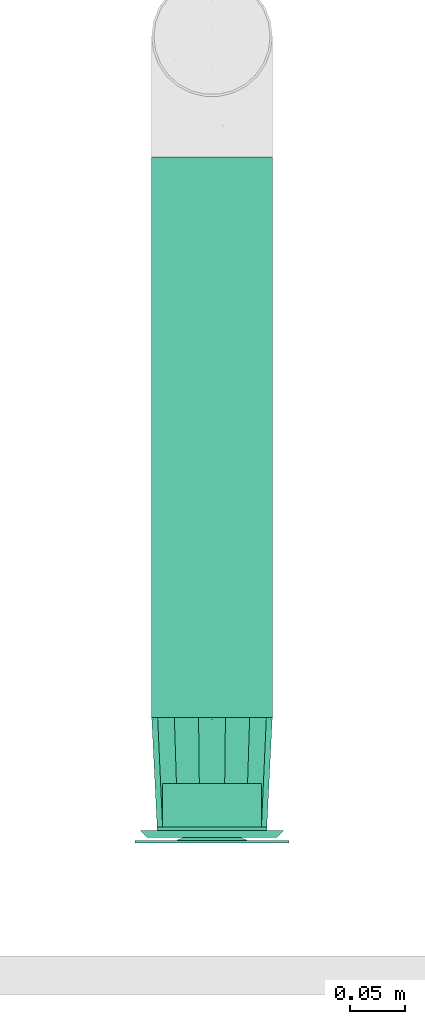
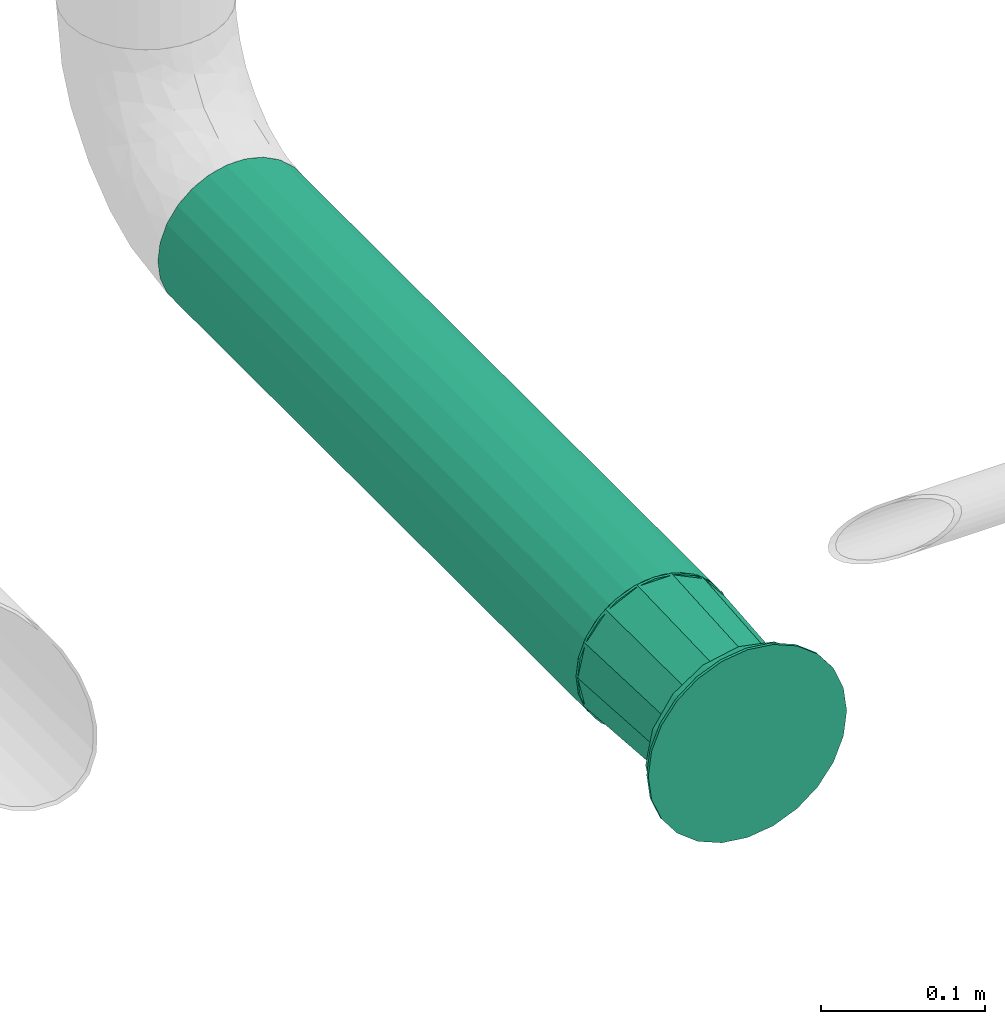
# One storey, part 104 of 123: 1 flow fitting, 1 flow segment, 1 flow terminal.
"""IFC2X3 building model written with IfcOpenShell, lengths in millimetres."""

from ifc_helpers import new_model, entity, si_unit, converted_unit, derived_unit, direction, frame, origin_with_axes, origin_2d_with_axis, place, context, subcontext, project, spatial, hollow_circle, extrude, open_shell, surface_model, source, transform, mapped, material, layer, layer_set, layer_usage, type_object, element, save


model = new_model("IFC2X3")

# Units and contexts
model_context = context("Model", 3, precision=1e-05, world=origin_with_axes(), true_north=direction((0.0, 1.0)))
body_context = subcontext(model_context, "Body", "Model", "MODEL_VIEW")
ifc_project = project(units=[si_unit("AREAUNIT", "SQUARE_METRE"), si_unit("VOLUMEUNIT", "CUBIC_METRE", prefix="DECI"), si_unit("TIMEUNIT", "SECOND"), si_unit("THERMODYNAMICTEMPERATUREUNIT", "DEGREE_CELSIUS"), si_unit("PRESSUREUNIT", "PASCAL"), si_unit("MASSUNIT", "GRAM", prefix="KILO"), si_unit("LENGTHUNIT", "METRE", prefix="MILLI"), si_unit("POWERUNIT", "WATT"), si_unit("ELECTRICCURRENTUNIT", "AMPERE"), si_unit("ELECTRICVOLTAGEUNIT", "VOLT"), derived_unit("VOLUMETRICFLOWRATEUNIT", [(si_unit("VOLUMEUNIT", "CUBIC_METRE", prefix="DECI"), 1), (si_unit("TIMEUNIT", "SECOND"), -1)]), derived_unit("LINEARVELOCITYUNIT", [(si_unit("LENGTHUNIT", "METRE"), 1), (si_unit("TIMEUNIT", "SECOND"), -1)]), derived_unit("MASSDENSITYUNIT", [(si_unit("MASSUNIT", "GRAM", prefix="KILO"), 1), (si_unit("VOLUMEUNIT", "CUBIC_METRE"), -1)]), converted_unit("PLANEANGLEUNIT", "DEGREE", entity("IfcRatioMeasure", 0.01745), si_unit("PLANEANGLEUNIT", "RADIAN"), dimensions=[0, 0, 0, 0, 0, 0, 0])], contexts=[model_context])

# Site, building, storey
site_placement = place(None, origin_with_axes())
site = spatial("IfcSite", under=ifc_project, at=site_placement, CompositionType="ELEMENT")
building_placement = place(site_placement, origin_with_axes())
building = spatial("IfcBuilding", under=site, at=building_placement, Name="mc-building", CompositionType="ELEMENT")
storey_placement = place(building_placement, origin_with_axes())
storey = spatial("IfcBuildingStorey", under=building, at=storey_placement, Name="1. Korrus", CompositionType="ELEMENT", Elevation=0.0)

# Flow terminal
air_terminal_type = type_object("IfcAirTerminalType", Name="100", PredefinedType="NOTDEFINED")
shared_shape_1 = source(origin_with_axes(), body_context, "Body", "SurfaceModel", [
    surface_model("IfcShellBasedSurfaceModel", [(11.2, 18.11733, -67.61481), (11.2, -18.11733, -67.61481), (11.2, 0.0, -70.0), (11.2, 67.61481, -18.11733), (11.2, 35.0, -60.62178), (11.2, 49.49747, -49.49747), (11.2, 60.62178, -35.0), (11.2, -67.61481, 18.11733), (11.2, -49.49747, -49.49747), (11.2, -67.61481, -18.11733), (11.2, -35.0, -60.62178), (11.2, -60.62178, -35.0), (11.2, -70.0, 0.0), (11.2, 18.11733, 67.61481), (11.2, 70.0, 0.0), (11.2, 67.61481, 18.11733), (11.2, 49.49747, 49.49747), (11.2, 60.62178, 35.0), (11.2, 35.0, 60.62178), (11.2, -49.49747, 49.49747), (11.2, -60.62178, 35.0), (11.2, -35.0, 60.62178), (11.2, -18.11733, 67.61481), (11.2, 0.0, 70.0), (9.2, 18.11733, 67.61481), (9.2, -67.61481, 18.11733), (9.2, 0.0, 70.0), (9.2, 49.49747, 49.49747), (9.2, 35.0, 60.62178), (9.2, 60.62178, 35.0), (9.2, 67.61481, 18.11733), (9.2, -35.0, 60.62178), (9.2, -49.49747, 49.49747), (9.2, -18.11733, 67.61481), (9.2, -60.62178, 35.0), (9.2, -67.61481, -18.11733), (9.2, -70.0, 0.0), (9.2, 67.61481, -18.11733), (9.2, 18.11733, -67.61481), (9.2, 49.49747, -49.49747), (9.2, 60.62178, -35.0), (9.2, 35.0, -60.62178), (9.2, -18.11733, -67.61481), (9.2, -49.49747, -49.49747), (9.2, -60.62178, -35.0), (9.2, -35.0, -60.62178), (9.2, 0.0, -70.0), (9.2, 70.0, 0.0), (9.2, 32.75, 0.0), (9.2, -16.375, 28.36233), (9.2, -28.36233, 16.375), (9.2, 16.375, 28.36233), (9.2, 0.0, 32.75), (9.2, 28.36233, 16.375), (9.2, -32.75, 0.0), (9.2, -16.375, -28.36233), (9.2, 16.375, -28.36233), (9.2, 0.0, -32.75), (9.2, 28.36233, -16.375), (9.2, -28.36233, -16.375), (6.2, -21.19625, -15.39997), (6.2, -21.19625, 15.39997), (6.2, 8.09625, 24.91768), (6.2, -8.09625, 24.91768), (6.2, -26.2, 0.0), (6.2, 21.19625, 15.39997), (6.2, -8.09625, -24.91768), (6.2, 21.19625, -15.39997), (6.2, 8.09625, -24.91768), (6.2, 26.2, 0.0), (9.2, 31.06579, -6.28555), (6.2, 23.69812, -7.69999), (6.2, -14.64625, -20.15883), (9.2, -22.36867, -22.36867), (6.2, -23.69812, -7.69999), (9.2, -31.06579, -6.28555), (6.2, 14.64625, -20.15883), (9.2, 8.1875, -30.55617), (6.2, 0.0, -24.91768), (9.2, 22.36867, -22.36867), (9.2, -8.1875, -30.55617), (9.2, -31.06579, 6.28555), (6.2, -23.69812, 7.69999), (6.2, 14.64625, 20.15883), (9.2, 22.36867, 22.36867), (6.2, 23.69812, 7.69999), (9.2, 31.06579, 6.28555), (6.2, -14.64625, 20.15883), (9.2, -8.1875, 30.55617), (6.2, 0.0, 24.91768), (9.2, -22.36867, 22.36867), (9.2, 8.1875, 30.55617), (6.2, -13.11761, 57.472), (6.2, -36.75472, 46.08897), (6.2, -53.11211, 25.57744), (6.2, 36.75472, 46.08897), (6.2, -58.95, 0.0), (6.2, 13.11761, 57.472), (6.2, 53.11211, 25.57744), (6.2, -53.11211, -25.57744), (6.2, -36.75472, -46.08897), (6.2, -13.11761, -57.472), (6.2, 58.95, 0.0), (6.2, 53.11211, -25.57744), (6.2, 13.11761, -57.472), (6.2, 36.75472, -46.08897), (0.0, -60.51411, 25.06576), (0.0, 0.0, 65.5), (0.0, 25.06576, 60.51411), (0.0, 46.3155, 46.3155), (0.0, 60.51411, 25.06576), (0.0, -46.3155, 46.3155), (0.0, -25.06576, 60.51411), (0.0, 0.0, -65.5), (0.0, -65.5, 0.0), (0.0, 65.5, 0.0), (0.0, 60.51411, -25.06576), (0.0, 46.3155, -46.3155), (0.0, 25.06576, -60.51411), (0.0, -46.3155, -46.3155), (0.0, -60.51411, -25.06576), (0.0, -25.06576, -60.51411), (6.2, 56.03105, -12.78872), (0.0, 53.4148, -35.69063), (0.0, 35.69063, -53.4148), (6.2, 24.93616, -51.78048), (0.0, -12.53288, -63.00706), (6.2, 0.0, -57.472), (0.0, -35.69063, -53.4148), (0.0, 63.00706, -12.53288), (6.2, 44.93342, -35.83321), (6.2, -24.93616, -51.78048), (6.2, -44.93342, -35.83321), (0.0, -53.4148, -35.69063), (0.0, 12.53288, -63.00706), (6.2, -56.03105, -12.78872), (0.0, -63.00706, -12.53288), (6.2, -56.03105, 12.78872), (0.0, -53.4148, 35.69063), (0.0, -35.69063, 53.4148), (6.2, -24.93616, 51.78048), (0.0, 12.53288, 63.00706), (6.2, 0.0, 57.472), (0.0, 35.69063, 53.4148), (0.0, -63.00706, 12.53288), (6.2, -44.93342, 35.83321), (6.2, 24.93616, 51.78048), (6.2, 44.93342, 35.83321), (0.0, 53.4148, 35.69063), (0.0, -12.53288, 63.00706), (6.2, 56.03105, 12.78872), (0.0, 63.00706, 12.53288), (-3.1, 12.94095, 48.29629), (-3.1, -35.35534, 35.35534), (-3.1, 0.0, 50.0), (-3.1, 35.35534, 35.35534), (-3.1, 25.0, 43.30127), (-3.1, -43.30127, 25.0), (-3.1, 43.30127, 25.0), (-3.1, -48.29629, -12.94095), (-3.1, -12.94095, 48.29629), (-3.1, -25.0, 43.30127), (-3.1, -50.0, 0.0), (-3.1, -48.29629, 12.94095), (-3.1, 48.29629, 12.94095), (-3.1, 12.94095, -48.29629), (-3.1, 50.0, 0.0), (-3.1, 48.29629, -12.94095), (-3.1, 35.35534, -35.35534), (-3.1, 43.30127, -25.0), (-3.1, 25.0, -43.30127), (-3.1, 0.0, -50.0), (-3.1, -35.35534, -35.35534), (-3.1, -43.30127, -25.0), (-3.1, -25.0, -43.30127), (-3.1, -12.94095, -48.29629), (0.0, 25.0, -43.30127), (0.0, 0.0, -50.0), (0.0, 12.94095, -48.29629), (0.0, 48.29629, -12.94095), (0.0, 35.35534, -35.35534), (0.0, -25.0, -43.30127), (0.0, 43.30127, -25.0), (0.0, -50.0, 0.0), (0.0, -12.94095, -48.29629), (0.0, -35.35534, -35.35534), (0.0, -48.29629, -12.94095), (0.0, -43.30127, -25.0), (0.0, 50.0, 0.0), (0.0, 43.30127, 25.0), (0.0, 12.94095, 48.29629), (0.0, 35.35534, 35.35534), (0.0, 25.0, 43.30127), (0.0, 0.0, 50.0), (0.0, -35.35534, 35.35534), (0.0, -43.30127, 25.0), (0.0, -48.29629, 12.94095), (0.0, -12.94095, 48.29629), (0.0, -25.0, 43.30127), (0.0, 48.29629, 12.94095), (-43.1, 0.0, 45.0), (-43.1, 11.64686, 43.46666), (-43.1, 22.5, 38.97115), (-43.1, -11.64686, 43.46666), (-43.1, 38.97115, 22.5), (-43.1, 43.46666, 11.64686), (-43.1, 31.81981, 31.81981), (-43.1, -22.5, 38.97115), (-43.1, -43.46666, 11.64686), (-43.1, -31.81981, 31.81981), (-43.1, -38.97115, 22.5), (-43.1, -45.0, 0.0), (-43.1, -43.46666, -11.64686), (-43.1, 45.0, 0.0), (-43.1, 43.46666, -11.64686), (-43.1, 38.97115, -22.5), (-43.1, 31.81981, -31.81981), (-43.1, 22.5, -38.97115), (-43.1, 11.64686, -43.46666), (-43.1, -31.81981, -31.81981), (-43.1, -38.97115, -22.5), (-43.1, -22.5, -38.97115), (-43.1, 0.0, -45.0), (-43.1, -11.64686, -43.46666), (-3.1, 22.5, -38.97115), (-3.1, 0.0, -45.0), (-3.1, 11.64686, -43.46666), (-3.1, 31.81981, -31.81981), (-3.1, -22.5, -38.97115), (-3.1, 38.97115, -22.5), (-3.1, 43.46666, -11.64686), (-3.1, 45.0, 0.0), (-3.1, -45.0, 0.0), (-3.1, -11.64686, -43.46666), (-3.1, -31.81981, -31.81981), (-3.1, -43.46666, -11.64686), (-3.1, -38.97115, -22.5), (-3.1, 0.0, 45.0), (-3.1, 43.46666, 11.64686), (-3.1, 38.97115, 22.5), (-3.1, 22.5, 38.97115), (-3.1, 31.81981, 31.81981), (-3.1, 11.64686, 43.46666), (-3.1, -11.64686, 43.46666), (-3.1, -43.46666, 11.64686), (-3.1, -31.81981, 31.81981), (-3.1, -38.97115, 22.5), (-3.1, -22.5, 38.97115)], [open_shell([[[0, 1, 2]], [[3, 0, 4]], [[5, 6, 3]], [[5, 3, 4]], [[7, 1, 0]], [[8, 7, 9]], [[10, 7, 8]], [[8, 9, 11]], [[12, 9, 7]], [[1, 7, 10]], [[7, 0, 3]], [[13, 14, 15]], [[16, 15, 17]], [[16, 18, 13]], [[16, 13, 15]], [[14, 13, 7]], [[7, 19, 20]], [[19, 7, 21]], [[7, 22, 21]], [[22, 7, 23]], [[7, 13, 23]], [[14, 7, 3]], [[24, 25, 26]], [[27, 24, 28]], [[27, 29, 30]], [[27, 30, 24]], [[25, 24, 30]], [[31, 25, 32]], [[25, 31, 33]], [[32, 25, 34]], [[33, 26, 25]], [[25, 35, 36]], [[25, 30, 37]], [[25, 37, 38]], [[39, 37, 40]], [[39, 41, 38]], [[39, 38, 37]], [[38, 42, 25]], [[35, 43, 44]], [[35, 25, 43]], [[45, 43, 25]], [[42, 45, 25]], [[38, 46, 42]], [[37, 30, 47]], [[35, 9, 36]], [[44, 11, 35]], [[10, 43, 45]], [[44, 43, 8]], [[1, 45, 42]], [[35, 11, 9]], [[9, 12, 36]], [[1, 10, 45]], [[8, 43, 10]], [[8, 11, 44]], [[2, 1, 42]], [[42, 46, 2]], [[38, 0, 46]], [[41, 4, 38]], [[6, 39, 40]], [[41, 39, 5]], [[3, 40, 37]], [[41, 5, 4]], [[4, 0, 38]], [[14, 3, 37]], [[6, 40, 3]], [[6, 5, 39]], [[47, 14, 37]], [[46, 0, 2]], [[30, 15, 47]], [[29, 17, 30]], [[18, 27, 28]], [[29, 27, 16]], [[13, 28, 24]], [[30, 17, 15]], [[15, 14, 47]], [[13, 18, 28]], [[16, 27, 18]], [[16, 17, 29]], [[23, 13, 24]], [[24, 26, 23]], [[33, 22, 26]], [[31, 21, 33]], [[20, 32, 34]], [[31, 32, 19]], [[7, 34, 25]], [[31, 19, 21]], [[21, 22, 33]], [[12, 7, 25]], [[20, 34, 7]], [[20, 19, 32]], [[36, 12, 25]], [[26, 22, 23]], [[48, 49, 50]], [[48, 51, 49]], [[49, 51, 52]], [[53, 51, 48]], [[48, 50, 54]], [[54, 55, 48]], [[56, 55, 57]], [[55, 58, 48]], [[58, 55, 56]], [[55, 54, 59]], [[60, 61, 62]], [[62, 61, 63]], [[64, 61, 60]], [[62, 65, 66]], [[67, 68, 65]], [[66, 60, 62]], [[65, 68, 66]], [[69, 67, 65]], [[69, 48, 70]], [[58, 71, 70]], [[72, 73, 60]], [[59, 74, 60]], [[75, 64, 74]], [[56, 68, 76]], [[72, 66, 55]], [[73, 72, 55]], [[68, 77, 78]], [[64, 75, 54]], [[59, 75, 74]], [[70, 71, 69]], [[67, 79, 76]], [[80, 55, 66]], [[68, 56, 77]], [[56, 76, 79]], [[79, 67, 58]], [[71, 58, 67]], [[80, 78, 57]], [[77, 57, 78]], [[66, 78, 80]], [[59, 60, 73]], [[64, 54, 81]], [[50, 82, 81]], [[83, 84, 65]], [[53, 85, 65]], [[86, 69, 85]], [[49, 63, 87]], [[83, 62, 51]], [[84, 83, 51]], [[63, 88, 89]], [[69, 86, 48]], [[53, 86, 85]], [[81, 82, 64]], [[61, 90, 87]], [[91, 51, 62]], [[63, 49, 88]], [[49, 87, 90]], [[90, 61, 50]], [[82, 50, 61]], [[91, 89, 52]], [[88, 52, 89]], [[62, 89, 91]], [[53, 65, 84]], [[92, 93, 94]], [[95, 94, 96]], [[97, 92, 95]], [[95, 92, 94]], [[96, 98, 95]], [[96, 99, 98]], [[99, 100, 101]], [[101, 102, 98]], [[102, 101, 103]], [[104, 105, 103]], [[101, 104, 103]], [[101, 98, 99]], [[106, 107, 108]], [[109, 110, 108]], [[106, 108, 110]], [[111, 112, 106]], [[106, 112, 107]], [[106, 113, 114]], [[106, 110, 113]], [[115, 116, 117]], [[117, 113, 110]], [[113, 117, 118]], [[114, 119, 120]], [[121, 119, 114]], [[121, 114, 113]], [[115, 117, 110]], [[103, 116, 122]], [[123, 116, 103]], [[124, 125, 118]], [[101, 126, 127]], [[100, 119, 128]], [[102, 122, 129]], [[103, 130, 123]], [[102, 129, 115]], [[113, 127, 126]], [[125, 124, 105]], [[130, 105, 117]], [[118, 125, 104]], [[124, 117, 105]], [[131, 100, 128]], [[119, 100, 132]], [[133, 99, 120]], [[134, 118, 104]], [[122, 116, 129]], [[127, 134, 104]], [[131, 121, 101]], [[99, 133, 132]], [[128, 121, 131]], [[130, 117, 123]], [[101, 121, 126]], [[99, 135, 120]], [[96, 136, 135]], [[136, 120, 135]], [[134, 127, 113]], [[133, 119, 132]], [[136, 96, 114]], [[94, 106, 137]], [[138, 106, 94]], [[139, 140, 112]], [[97, 141, 142]], [[95, 109, 143]], [[96, 137, 144]], [[94, 145, 138]], [[96, 144, 114]], [[107, 142, 141]], [[140, 139, 93]], [[145, 93, 111]], [[112, 140, 92]], [[139, 111, 93]], [[146, 95, 143]], [[109, 95, 147]], [[148, 98, 110]], [[149, 112, 92]], [[137, 106, 144]], [[142, 149, 92]], [[146, 108, 97]], [[98, 148, 147]], [[143, 108, 146]], [[145, 111, 138]], [[97, 108, 141]], [[98, 150, 110]], [[102, 151, 150]], [[151, 110, 150]], [[149, 142, 107]], [[148, 109, 147]], [[151, 102, 115]], [[152, 153, 154]], [[155, 152, 156]], [[157, 152, 158]], [[158, 152, 155]], [[158, 159, 157]], [[160, 153, 161]], [[160, 154, 153]], [[157, 162, 163]], [[153, 152, 157]], [[157, 159, 162]], [[158, 164, 159]], [[165, 166, 167]], [[168, 167, 169]], [[170, 165, 167]], [[170, 167, 168]], [[166, 165, 171]], [[159, 172, 173]], [[172, 159, 174]], [[174, 171, 175]], [[159, 164, 174]], [[166, 171, 174]], [[174, 164, 166]], [[176, 177, 178]], [[179, 176, 180]], [[176, 179, 181]], [[179, 180, 182]], [[179, 183, 181]], [[177, 181, 184]], [[177, 176, 181]], [[185, 186, 187]], [[186, 185, 181]], [[181, 183, 186]], [[183, 179, 188]], [[183, 188, 189]], [[190, 189, 191]], [[189, 190, 183]], [[190, 191, 192]], [[193, 194, 190]], [[183, 195, 196]], [[183, 190, 195]], [[194, 197, 198]], [[194, 195, 190]], [[197, 194, 193]], [[189, 188, 199]], [[164, 199, 166]], [[158, 189, 164]], [[192, 155, 156]], [[158, 155, 191]], [[190, 156, 152]], [[164, 189, 199]], [[199, 188, 166]], [[190, 192, 156]], [[191, 155, 192]], [[191, 189, 158]], [[193, 190, 152]], [[152, 154, 193]], [[160, 197, 154]], [[161, 198, 160]], [[195, 153, 157]], [[161, 153, 194]], [[196, 157, 163]], [[161, 194, 198]], [[198, 197, 160]], [[183, 196, 163]], [[195, 157, 196]], [[195, 194, 153]], [[162, 183, 163]], [[154, 197, 193]], [[159, 186, 162]], [[173, 187, 159]], [[181, 172, 174]], [[173, 172, 185]], [[184, 174, 175]], [[159, 187, 186]], [[186, 183, 162]], [[184, 181, 174]], [[185, 172, 181]], [[185, 187, 173]], [[177, 184, 175]], [[175, 171, 177]], [[165, 178, 171]], [[170, 176, 165]], [[182, 168, 169]], [[170, 168, 180]], [[179, 169, 167]], [[170, 180, 176]], [[176, 178, 165]], [[188, 179, 167]], [[182, 169, 179]], [[182, 180, 168]], [[166, 188, 167]], [[171, 178, 177]], [[200, 201, 202]], [[203, 200, 202]], [[204, 205, 202]], [[204, 202, 206]], [[203, 202, 205]], [[207, 208, 209]], [[207, 203, 205]], [[209, 208, 210]], [[211, 208, 212]], [[208, 207, 212]], [[207, 205, 212]], [[213, 214, 215]], [[205, 215, 212]], [[212, 216, 217]], [[216, 212, 215]], [[218, 219, 217]], [[212, 219, 220]], [[212, 217, 219]], [[221, 222, 223]], [[222, 221, 219]], [[218, 222, 219]], [[215, 205, 213]], [[224, 225, 226]], [[227, 228, 224]], [[229, 230, 231]], [[228, 227, 229]], [[229, 232, 228]], [[225, 228, 233]], [[225, 224, 228]], [[234, 235, 236]], [[235, 234, 228]], [[228, 232, 235]], [[232, 229, 231]], [[237, 238, 239]], [[240, 239, 241]], [[240, 242, 237]], [[240, 237, 239]], [[238, 237, 243]], [[244, 245, 246]], [[247, 244, 232]], [[244, 247, 245]], [[232, 238, 247]], [[238, 243, 247]], [[238, 232, 231]], [[205, 238, 213]], [[204, 239, 205]], [[240, 206, 202]], [[204, 206, 241]], [[242, 202, 201]], [[205, 239, 238]], [[238, 231, 213]], [[240, 202, 242]], [[241, 206, 240]], [[241, 239, 204]], [[201, 237, 242]], [[201, 200, 237]], [[243, 203, 207]], [[209, 247, 207]], [[246, 210, 208]], [[209, 210, 245]], [[244, 208, 211]], [[203, 243, 200]], [[207, 247, 243]], [[200, 243, 237]], [[209, 245, 247]], [[210, 246, 245]], [[244, 246, 208]], [[211, 232, 244]], [[212, 235, 211]], [[220, 236, 212]], [[228, 219, 221]], [[220, 219, 234]], [[233, 221, 223]], [[212, 236, 235]], [[235, 232, 211]], [[233, 228, 221]], [[234, 219, 228]], [[234, 236, 220]], [[225, 233, 223]], [[223, 222, 225]], [[226, 218, 217]], [[216, 224, 217]], [[229, 215, 214]], [[216, 215, 227]], [[230, 214, 213]], [[218, 226, 222]], [[217, 224, 226]], [[222, 226, 225]], [[216, 227, 224]], [[215, 229, 227]], [[230, 229, 214]], [[213, 231, 230]]])]),
])
flow_terminal_placement = place(storey_placement, frame((30364.56773, 12939.66532, 2300.0), z_axis=(0.0, 0.0, 1.0), x_axis=(0.0, -1.0, 0.0)))
element("IfcFlowTerminal", 1, at=flow_terminal_placement, inside=storey, type_object=air_terminal_type, Name="100", context=body_context, shape_type="MappedRepresentation", body=[
    mapped(shared_shape_1, transform((0.0, 0.0, 0.0), scale=1.0)),
])

# Flow segment
ifc_material = material(Name="FZ1")
ifc_layer = layer(ifc_material, 0.0)
ifc_layer_set = layer_set([ifc_layer], Name="FZ1")
ifc_layer_usage = layer_usage(ifc_layer_set, "AXIS1", "POSITIVE", 0.0)
duct_segment_type = type_object("IfcDuctSegmentType", PredefinedType="RIGIDSEGMENT")
shared_shape_2 = source(origin_with_axes(), body_context, "Body", "SweptSolid", [
    extrude(hollow_circle(Radius=55.0, WallThickness=2.0, at=origin_2d_with_axis()), frame((0.0, 0.0, 0.0), z_axis=(1.0, 0.0, 0.0), x_axis=(0.0, 1.0, 0.0)), (0.0, 0.0, 1.0), 510.8),
])
flow_segment_placement = place(storey_placement, frame((30364.56773, 13042.76532, 2300.0), z_axis=(0.0, 0.0, 1.0), x_axis=(0.0, 1.0, 0.0)))
element("IfcFlowSegment", 2, at=flow_segment_placement, inside=storey, type_object=duct_segment_type, material=ifc_layer_usage, context=body_context, shape_type="MappedRepresentation", body=[
    mapped(shared_shape_2, transform((0.0, 0.0, 0.0), scale=1.0)),
])

# Flow fitting
duct_fitting_type = type_object("IfcDuctFittingType", PredefinedType="TRANSITION")
shared_shape_3 = source(origin_with_axes(), body_context, "Body", "SurfaceModel", [
    surface_model("IfcShellBasedSurfaceModel", [(0.0, 12.94095, 48.29629), (0.0, -35.35534, 35.35534), (0.0, 0.0, 50.0), (0.0, 35.35534, 35.35534), (0.0, 25.0, 43.30127), (0.0, 43.30127, 25.0), (0.0, 48.29629, 12.94095), (0.0, -12.94095, 48.29629), (0.0, -25.0, 43.30127), (0.0, -48.29629, 12.94095), (0.0, -43.30127, 25.0), (0.0, -25.0, -43.30127), (0.0, -48.29629, -12.94095), (0.0, -50.0, 0.0), (0.0, 48.29629, -12.94095), (0.0, 12.94095, -48.29629), (0.0, 43.30127, -25.0), (0.0, 35.35534, -35.35534), (0.0, 25.0, -43.30127), (0.0, -35.35534, -35.35534), (0.0, -43.30127, -25.0), (0.0, -12.94095, -48.29629), (0.0, 0.0, -50.0), (0.0, 50.0, 0.0), (100.0, -55.0, 0.0), (100.0, -12.23865, 53.62104), (100.0, -34.29194, 43.00073), (100.0, 49.55329, -23.86361), (100.0, 12.23865, 53.62104), (100.0, 34.29194, 43.00073), (100.0, 55.0, 0.0), (100.0, 49.55329, 23.86361), (100.0, -49.55329, 23.86361), (100.0, 12.23865, -53.62104), (100.0, -49.55329, -23.86361), (100.0, -34.29194, -43.00073), (100.0, 34.29194, -43.00073), (100.0, -12.23865, -53.62104), (0.0, 11.12605, 48.7464), (0.0, -11.12605, 48.7464), (0.0, 31.17449, 39.09157), (0.0, -45.04844, -21.69419), (0.0, -45.04844, 21.69419), (0.0, -31.17449, 39.09157), (0.0, 45.04844, 21.69419), (0.0, 45.04844, -21.69419), (0.0, 31.17449, -39.09157), (0.0, -31.17449, -39.09157), (0.0, -11.12605, -48.7464), (0.0, 11.12605, -48.7464), (0.0, -47.52422, -10.84709), (100.0, -41.92261, -33.43217), (0.0, -38.11147, -30.39288), (100.0, 41.92261, -33.43217), (0.0, 38.11147, -30.39288), (0.0, -21.15027, -43.91899), (100.0, -23.2653, -48.31088), (100.0, -52.32388, -11.72483), (100.0, 0.0, -53.62104), (0.0, 0.0, -48.7464), (100.0, 23.2653, -48.31088), (0.0, 21.15027, -43.91899), (100.0, 52.32388, -11.72483), (0.0, 47.52422, -10.84709), (0.0, 47.52422, 10.84709), (100.0, 41.92261, 33.43217), (0.0, 38.11147, 30.39288), (100.0, -41.92261, 33.43217), (0.0, -38.11147, 30.39288), (0.0, 21.15027, 43.91899), (100.0, 23.2653, 48.31088), (100.0, 52.32388, 11.72483), (100.0, 0.0, 53.62104), (0.0, 0.0, 48.7464), (100.0, -23.2653, 48.31088), (0.0, -21.15027, 43.91899), (100.0, -52.32388, 11.72483), (0.0, -47.52422, 10.84709), (100.0, 27.5, -47.63139), (100.0, 0.0, -55.0), (100.0, 14.23505, -53.12592), (100.0, 38.89087, -38.89087), (100.0, -27.5, -47.63139), (100.0, 47.63139, -27.5), (100.0, 53.12592, -14.23505), (100.0, -14.23505, -53.12592), (100.0, -47.63139, -27.5), (100.0, -38.89087, -38.89087), (100.0, -53.12592, -14.23505), (100.0, 53.12592, 14.23505), (100.0, 47.63139, 27.5), (100.0, 27.5, 47.63139), (100.0, 38.89087, 38.89087), (100.0, 14.23505, 53.12592), (100.0, 0.0, 55.0), (100.0, -47.63139, 27.5), (100.0, -53.12592, 14.23505), (100.0, -27.5, 47.63139), (100.0, -38.89087, 38.89087), (100.0, -14.23505, 53.12592), (98.0, 0.0, 55.0), (98.0, 14.23505, 53.12592), (98.0, 27.5, 47.63139), (98.0, 38.89087, 38.89087), (98.0, 47.63139, 27.5), (98.0, -47.63139, 27.5), (98.0, 53.12592, -14.23505), (98.0, -27.5, 47.63139), (98.0, -14.23505, 53.12592), (98.0, -38.89087, 38.89087), (98.0, -55.0, 0.0), (98.0, -53.12592, 14.23505), (98.0, 53.12592, 14.23505), (98.0, 47.63139, -27.5), (98.0, -27.5, -47.63139), (98.0, 0.0, -55.0), (98.0, 38.89087, -38.89087), (98.0, 27.5, -47.63139), (98.0, 14.23505, -53.12592), (98.0, -47.63139, -27.5), (98.0, -38.89087, -38.89087), (98.0, -53.12592, -14.23505), (98.0, -14.23505, -53.12592), (98.0, 55.0, 0.0), (2.0, 12.94095, -48.29629), (2.0, 25.0, -43.30127), (2.0, 35.35534, -35.35534), (2.0, 43.30127, -25.0), (2.0, 48.29629, -12.94095), (2.0, 0.0, -50.0), (2.0, 50.0, 0.0), (2.0, -25.0, -43.30127), (2.0, -12.94095, -48.29629), (2.0, -35.35534, -35.35534), (2.0, -48.29629, -12.94095), (2.0, -43.30127, -25.0), (2.0, -48.29629, 12.94095), (2.0, 48.29629, 12.94095), (2.0, 43.30127, 25.0), (2.0, 35.35534, 35.35534), (2.0, -35.35534, 35.35534), (2.0, 12.94095, 48.29629), (2.0, 25.0, 43.30127), (2.0, 0.0, 50.0), (2.0, -43.30127, 25.0), (2.0, -50.0, 0.0), (2.0, -12.94095, 48.29629), (2.0, -25.0, 43.30127)], [open_shell([[[0, 1, 2]], [[3, 0, 4]], [[3, 5, 6]], [[0, 3, 1]], [[6, 1, 3]], [[7, 1, 8]], [[7, 2, 1]], [[1, 9, 10]], [[9, 1, 11]], [[12, 13, 9]], [[11, 1, 6]], [[6, 14, 11]], [[15, 14, 16]], [[17, 18, 15]], [[17, 15, 16]], [[11, 14, 15]], [[12, 19, 20]], [[19, 12, 11]], [[15, 21, 11]], [[12, 9, 11]], [[22, 21, 15]], [[14, 6, 23]], [[24, 25, 26]], [[25, 27, 28]], [[29, 28, 27]], [[27, 30, 31]], [[31, 29, 27]], [[24, 26, 32]], [[33, 24, 34]], [[33, 34, 35]], [[36, 27, 33]], [[33, 27, 24]], [[35, 37, 33]], [[24, 27, 25]], [[38, 23, 39]], [[40, 23, 38]], [[41, 42, 43]], [[41, 13, 42]], [[23, 43, 39]], [[40, 44, 23]], [[41, 23, 45]], [[41, 45, 46]], [[47, 41, 48]], [[49, 48, 41]], [[41, 46, 49]], [[23, 41, 43]], [[34, 50, 41]], [[47, 51, 52]], [[45, 27, 53]], [[36, 54, 53]], [[55, 48, 56]], [[34, 57, 50]], [[57, 13, 50]], [[13, 57, 24]], [[55, 35, 47]], [[35, 51, 47]], [[51, 41, 52]], [[58, 59, 49]], [[60, 61, 46]], [[37, 59, 58]], [[62, 63, 23]], [[35, 55, 56]], [[23, 30, 62]], [[53, 54, 45]], [[48, 37, 56]], [[33, 49, 61]], [[49, 33, 58]], [[54, 36, 46]], [[63, 27, 45]], [[34, 41, 51]], [[33, 61, 60]], [[48, 59, 37]], [[27, 63, 62]], [[46, 36, 60]], [[31, 64, 44]], [[40, 65, 66]], [[42, 32, 67]], [[26, 68, 67]], [[69, 38, 70]], [[31, 71, 64]], [[71, 23, 64]], [[23, 71, 30]], [[69, 29, 40]], [[29, 65, 40]], [[65, 44, 66]], [[72, 73, 39]], [[74, 75, 43]], [[28, 73, 72]], [[76, 77, 13]], [[29, 69, 70]], [[13, 24, 76]], [[67, 68, 42]], [[38, 28, 70]], [[25, 39, 75]], [[39, 25, 72]], [[68, 26, 43]], [[77, 32, 42]], [[31, 44, 65]], [[25, 75, 74]], [[38, 73, 28]], [[32, 77, 76]], [[43, 26, 74]], [[78, 79, 80]], [[81, 82, 78]], [[82, 83, 84]], [[81, 83, 82]], [[30, 82, 84]], [[79, 82, 85]], [[79, 78, 82]], [[82, 86, 87]], [[82, 30, 86]], [[24, 88, 86]], [[86, 30, 89]], [[90, 24, 89]], [[91, 90, 92]], [[91, 93, 94]], [[90, 91, 24]], [[94, 95, 91]], [[24, 95, 96]], [[24, 91, 95]], [[94, 97, 98]], [[98, 95, 94]], [[97, 94, 99]], [[89, 24, 86]], [[100, 101, 102]], [[100, 102, 103]], [[100, 104, 105]], [[104, 100, 103]], [[106, 105, 104]], [[100, 107, 108]], [[100, 109, 107]], [[105, 110, 111]], [[109, 100, 105]], [[105, 106, 110]], [[106, 104, 112]], [[106, 113, 110]], [[113, 114, 110]], [[115, 116, 117]], [[113, 116, 115]], [[117, 118, 115]], [[119, 114, 120]], [[121, 110, 119]], [[114, 115, 122]], [[119, 110, 114]], [[115, 114, 113]], [[123, 106, 112]], [[121, 88, 110]], [[119, 86, 121]], [[82, 120, 114]], [[119, 120, 87]], [[85, 114, 122]], [[121, 86, 88]], [[88, 24, 110]], [[85, 82, 114]], [[87, 120, 82]], [[87, 86, 119]], [[79, 85, 122]], [[122, 115, 79]], [[118, 80, 115]], [[117, 78, 118]], [[83, 116, 113]], [[117, 116, 81]], [[84, 113, 106]], [[117, 81, 78]], [[78, 80, 118]], [[30, 84, 106]], [[83, 113, 84]], [[83, 81, 116]], [[123, 30, 106]], [[115, 80, 79]], [[112, 89, 123]], [[104, 90, 112]], [[91, 103, 102]], [[104, 103, 92]], [[93, 102, 101]], [[112, 90, 89]], [[89, 30, 123]], [[93, 91, 102]], [[92, 103, 91]], [[92, 90, 104]], [[94, 93, 101]], [[101, 100, 94]], [[108, 99, 100]], [[107, 97, 108]], [[95, 109, 105]], [[107, 109, 98]], [[96, 105, 111]], [[107, 98, 97]], [[97, 99, 108]], [[24, 96, 111]], [[95, 105, 96]], [[95, 98, 109]], [[110, 24, 111]], [[100, 99, 94]], [[124, 125, 126]], [[124, 126, 127]], [[124, 128, 129]], [[128, 124, 127]], [[129, 128, 130]], [[129, 131, 132]], [[129, 130, 131]], [[133, 134, 135]], [[134, 133, 131]], [[131, 136, 134]], [[131, 130, 137]], [[137, 138, 139]], [[140, 137, 139]], [[140, 139, 141]], [[141, 139, 142]], [[140, 141, 143]], [[136, 140, 144]], [[145, 134, 136]], [[140, 146, 147]], [[131, 140, 136]], [[143, 146, 140]], [[131, 137, 140]], [[12, 134, 13]], [[20, 135, 12]], [[131, 19, 11]], [[20, 19, 133]], [[132, 11, 21]], [[12, 135, 134]], [[134, 145, 13]], [[132, 131, 11]], [[133, 19, 131]], [[133, 135, 20]], [[129, 132, 21]], [[21, 22, 129]], [[15, 124, 22]], [[18, 125, 15]], [[127, 17, 16]], [[18, 17, 126]], [[128, 16, 14]], [[18, 126, 125]], [[125, 124, 15]], [[130, 128, 14]], [[127, 16, 128]], [[127, 126, 17]], [[23, 130, 14]], [[22, 124, 129]], [[6, 137, 23]], [[5, 138, 6]], [[142, 3, 4]], [[5, 3, 139]], [[141, 4, 0]], [[6, 138, 137]], [[137, 130, 23]], [[141, 142, 4]], [[139, 3, 142]], [[139, 138, 5]], [[143, 141, 0]], [[0, 2, 143]], [[7, 146, 2]], [[8, 147, 7]], [[144, 1, 10]], [[8, 1, 140]], [[136, 10, 9]], [[8, 140, 147]], [[147, 146, 7]], [[145, 136, 9]], [[144, 10, 136]], [[144, 140, 1]], [[13, 145, 9]], [[2, 146, 143]]])]),
])
flow_fitting_placement = place(storey_placement, frame((30364.56773, 12942.76532, 2300.0), z_axis=(0.0, 0.0, 1.0), x_axis=(0.0, 1.0, 0.0)))
element("IfcFlowFitting", 3, at=flow_fitting_placement, inside=storey, type_object=duct_fitting_type, context=body_context, shape_type="MappedRepresentation", body=[
    mapped(shared_shape_3, transform((0.0, 0.0, 0.0), scale=1.0)),
])

save(model, "model.ifc")
